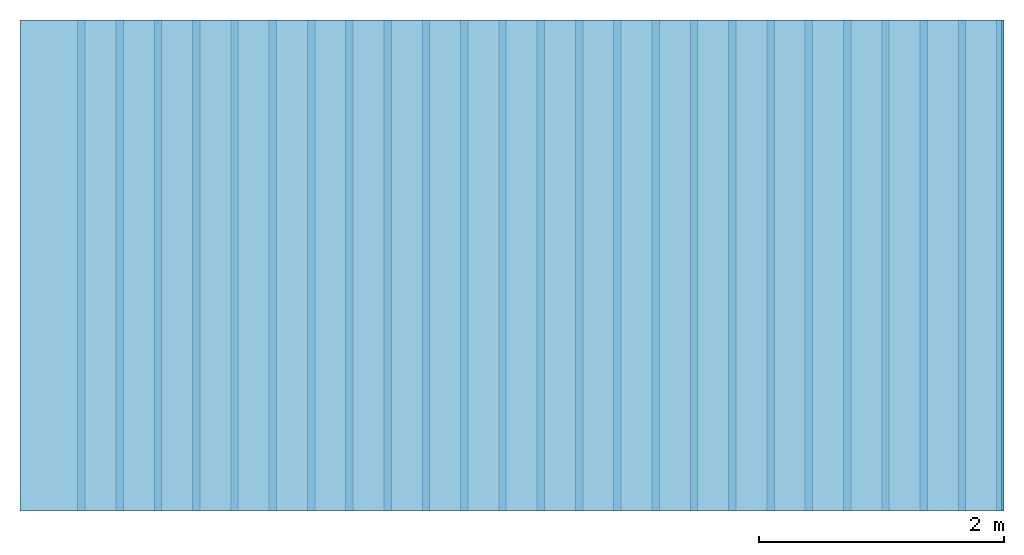
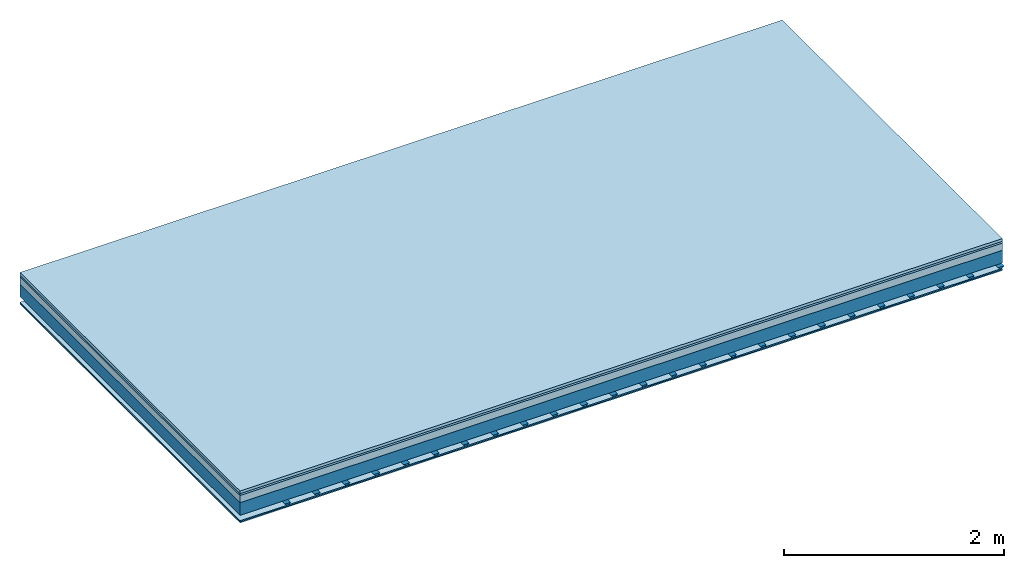
# One storey: 5 plates, 2 members, 1 element without a shape of its own.
"""IFC4 building model written with IfcOpenShell, lengths in metres."""

from ifc_helpers import new_model, si_unit, derived_unit, direction, frame, frame_2d, origin, origin_with_axes, place, context, project, spatial, polyline, rectangle, outline, extrude, material, layer, layer_set, type_object, element, aggregate, save


model = new_model("IFC4")

# Units and contexts
plan_context = context("Plan", 3, precision=1e-05, world=origin(), true_north=direction((0.0, 1.0)))
model_context = context("Model", 3, precision=1e-05, world=origin(), true_north=direction((0.0, 1.0)))
ifc_project = project(units=[si_unit("LENGTHUNIT", "METRE"), derived_unit("SOUNDPRESSUREUNIT", [(si_unit("PRESSUREUNIT", "PASCAL", prefix="MICRO"), 0)]), si_unit("ENERGYUNIT", "JOULE", prefix="MEGA"), si_unit("MASSUNIT", "GRAM", prefix="KILO"), derived_unit("THERMALTRANSMITTANCEUNIT", [(si_unit("POWERUNIT", "WATT"), 1), (si_unit("AREAUNIT", "SQUARE_METRE"), -1), (si_unit("THERMODYNAMICTEMPERATUREUNIT", "KELVIN"), -1)]), derived_unit("AREADENSITYUNIT", [(si_unit("MASSUNIT", "GRAM", prefix="KILO"), 1), (si_unit("AREAUNIT", "SQUARE_METRE"), -1)]), derived_unit("USERDEFINED", [(si_unit("ENERGYUNIT", "JOULE", prefix="MEGA"), 1), (si_unit("AREAUNIT", "SQUARE_METRE"), -1)])], contexts=[plan_context, model_context])

# Site, building, storey
site = spatial("IfcSite", under=ifc_project)
building_placement = place(None, origin())
building = spatial("IfcBuilding", under=site, at=building_placement)
storey_placement = place(building_placement, origin())
storey = spatial("IfcBuildingStorey", under=building, at=storey_placement)

# Slab, members, plates
ifc_material_1 = material(Name="Phone Star TRI", Category="03.013")
ifc_layer_1 = layer(ifc_material_1, 0.03, Name="On-material")
ifc_material_2 = material(Name="EP3")
ifc_layer_2 = layer(ifc_material_2, 0.02, Name="Impact sound insulation")
ifc_material_3 = material(Category="03.011")
ifc_layer_3 = layer(ifc_material_3, 0.08, Name="on Supporting structure")
ifc_material_4 = material(Name="no composite action")
ifc_layer_4 = layer(ifc_material_4, 0.0, Name="Bond")
ifc_layer_5 = layer(None, 0.14, Name="Supporting structure")
ifc_material_5 = material(Name="of the art")
ifc_layer_6 = layer(ifc_material_5, 0.0, Name="Bond")
ifc_layer_7 = layer(None, 0.06, Name="Coupling")
ifc_layer_8 = layer(ifc_material_1, 0.0125, Name="Ceiling covering 1st layer")
ifc_material_6 = material(Name="Plasterboard type A", Category="03.008")
ifc_layer_9 = layer(ifc_material_6, 0.0125, Name="Ceiling covering layer 2")
ifc_material_7 = material(Name="joints", Category="04.017")
ifc_layer_10 = layer(ifc_material_7, 0.0, Name="Surface / treatment")
ifc_layer_set = layer_set([ifc_layer_1, ifc_layer_2, ifc_layer_3, ifc_layer_4, ifc_layer_5, ifc_layer_6, ifc_layer_7, ifc_layer_8, ifc_layer_9, ifc_layer_10])
slab_type = type_object("IfcSlabType", Name="A2425", PredefinedType="NOTDEFINED", material=ifc_layer_set)
slab_placement = place(None, frame((0.0, 0.0, 0.0), z_axis=(0.0, 0.0, -1.0), x_axis=(1.0, 0.0, 0.0)))
slab = element("IfcSlab", 1, at=slab_placement, inside=storey, type_object=slab_type, material=ifc_layer_set, Name="Slab #1")
ifc_material_8 = material()
member_1_placement = place(slab_placement, origin())
member_1 = element("IfcMember", 2, at=member_1_placement, material=ifc_material_8, Name="Supporting structure", context=plan_context, shape_type="SweptSolid", body=[
    extrude(rectangle(XDim=1.0, YDim=0.14, at=frame_2d((0.5, 0.07), x_axis=(1.0, 0.0))), frame((0.0, 4.0, 0.13), z_axis=(0.0, -1.0, 0.0), x_axis=(1.0, 0.0, 0.0)), (0.0, 0.0, 1.0), 4.0),
    extrude(rectangle(XDim=1.0, YDim=0.14, at=frame_2d((0.5, 0.07), x_axis=(1.0, 0.0))), frame((1.0, 4.0, 0.13), z_axis=(0.0, -1.0, 0.0), x_axis=(1.0, 0.0, 0.0)), (0.0, 0.0, 1.0), 4.0),
    extrude(rectangle(XDim=1.0, YDim=0.14, at=frame_2d((0.5, 0.07), x_axis=(1.0, 0.0))), frame((2.0, 4.0, 0.13), z_axis=(0.0, -1.0, 0.0), x_axis=(1.0, 0.0, 0.0)), (0.0, 0.0, 1.0), 4.0),
    extrude(rectangle(XDim=1.0, YDim=0.14, at=frame_2d((0.5, 0.07), x_axis=(1.0, 0.0))), frame((3.0, 4.0, 0.13), z_axis=(0.0, -1.0, 0.0), x_axis=(1.0, 0.0, 0.0)), (0.0, 0.0, 1.0), 4.0),
    extrude(rectangle(XDim=1.0, YDim=0.14, at=frame_2d((0.5, 0.07), x_axis=(1.0, 0.0))), frame((4.0, 4.0, 0.13), z_axis=(0.0, -1.0, 0.0), x_axis=(1.0, 0.0, 0.0)), (0.0, 0.0, 1.0), 4.0),
    extrude(rectangle(XDim=1.0, YDim=0.14, at=frame_2d((0.5, 0.07), x_axis=(1.0, 0.0))), frame((5.0, 4.0, 0.13), z_axis=(0.0, -1.0, 0.0), x_axis=(1.0, 0.0, 0.0)), (0.0, 0.0, 1.0), 4.0),
    extrude(rectangle(XDim=1.0, YDim=0.14, at=frame_2d((0.5, 0.07), x_axis=(1.0, 0.0))), frame((6.0, 4.0, 0.13), z_axis=(0.0, -1.0, 0.0), x_axis=(1.0, 0.0, 0.0)), (0.0, 0.0, 1.0), 4.0),
    extrude(rectangle(XDim=1.0, YDim=0.14, at=frame_2d((0.5, 0.07), x_axis=(1.0, 0.0))), frame((7.0, 4.0, 0.13), z_axis=(0.0, -1.0, 0.0), x_axis=(1.0, 0.0, 0.0)), (0.0, 0.0, 1.0), 4.0),
])
ifc_material_9 = material()
member_2_placement = place(slab_placement, origin())
member_2 = element("IfcMember", 3, at=member_2_placement, material=ifc_material_9, Name="Coupling", context=plan_context, shape_type="SweptSolid", body=[
    extrude(outline(polyline([(0.0, 0.0), (0.06, 0.0), (0.04, 0.02), (0.02, 0.02), (0.0, 0.0)])), frame((0.47, 4.0, 0.31), z_axis=(0.0, -1.0, 0.0), x_axis=(1.0, 0.0, 0.0)), (0.0, 0.0, 1.0), 4.0),
    extrude(outline(polyline([(0.0, 0.0), (0.06, 0.0), (0.04, 0.02), (0.02, 0.02), (0.0, 0.0)])), frame((0.782, 4.0, 0.31), z_axis=(0.0, -1.0, 0.0), x_axis=(1.0, 0.0, 0.0)), (0.0, 0.0, 1.0), 4.0),
    extrude(outline(polyline([(0.0, 0.0), (0.06, 0.0), (0.04, 0.02), (0.02, 0.02), (0.0, 0.0)])), frame((1.094, 4.0, 0.31), z_axis=(0.0, -1.0, 0.0), x_axis=(1.0, 0.0, 0.0)), (0.0, 0.0, 1.0), 4.0),
    extrude(outline(polyline([(0.0, 0.0), (0.06, 0.0), (0.04, 0.02), (0.02, 0.02), (0.0, 0.0)])), frame((1.406, 4.0, 0.31), z_axis=(0.0, -1.0, 0.0), x_axis=(1.0, 0.0, 0.0)), (0.0, 0.0, 1.0), 4.0),
    extrude(outline(polyline([(0.0, 0.0), (0.06, 0.0), (0.04, 0.02), (0.02, 0.02), (0.0, 0.0)])), frame((1.718, 4.0, 0.31), z_axis=(0.0, -1.0, 0.0), x_axis=(1.0, 0.0, 0.0)), (0.0, 0.0, 1.0), 4.0),
    extrude(outline(polyline([(0.0, 0.0), (0.06, 0.0), (0.04, 0.02), (0.02, 0.02), (0.0, 0.0)])), frame((2.03, 4.0, 0.31), z_axis=(0.0, -1.0, 0.0), x_axis=(1.0, 0.0, 0.0)), (0.0, 0.0, 1.0), 4.0),
    extrude(outline(polyline([(0.0, 0.0), (0.06, 0.0), (0.04, 0.02), (0.02, 0.02), (0.0, 0.0)])), frame((2.342, 4.0, 0.31), z_axis=(0.0, -1.0, 0.0), x_axis=(1.0, 0.0, 0.0)), (0.0, 0.0, 1.0), 4.0),
    extrude(outline(polyline([(0.0, 0.0), (0.06, 0.0), (0.04, 0.02), (0.02, 0.02), (0.0, 0.0)])), frame((2.654, 4.0, 0.31), z_axis=(0.0, -1.0, 0.0), x_axis=(1.0, 0.0, 0.0)), (0.0, 0.0, 1.0), 4.0),
    extrude(outline(polyline([(0.0, 0.0), (0.06, 0.0), (0.04, 0.02), (0.02, 0.02), (0.0, 0.0)])), frame((2.966, 4.0, 0.31), z_axis=(0.0, -1.0, 0.0), x_axis=(1.0, 0.0, 0.0)), (0.0, 0.0, 1.0), 4.0),
    extrude(outline(polyline([(0.0, 0.0), (0.06, 0.0), (0.04, 0.02), (0.02, 0.02), (0.0, 0.0)])), frame((3.278, 4.0, 0.31), z_axis=(0.0, -1.0, 0.0), x_axis=(1.0, 0.0, 0.0)), (0.0, 0.0, 1.0), 4.0),
    extrude(outline(polyline([(0.0, 0.0), (0.06, 0.0), (0.04, 0.02), (0.02, 0.02), (0.0, 0.0)])), frame((3.59, 4.0, 0.31), z_axis=(0.0, -1.0, 0.0), x_axis=(1.0, 0.0, 0.0)), (0.0, 0.0, 1.0), 4.0),
    extrude(outline(polyline([(0.0, 0.0), (0.06, 0.0), (0.04, 0.02), (0.02, 0.02), (0.0, 0.0)])), frame((3.902, 4.0, 0.31), z_axis=(0.0, -1.0, 0.0), x_axis=(1.0, 0.0, 0.0)), (0.0, 0.0, 1.0), 4.0),
    extrude(outline(polyline([(0.0, 0.0), (0.06, 0.0), (0.04, 0.02), (0.02, 0.02), (0.0, 0.0)])), frame((4.214, 4.0, 0.31), z_axis=(0.0, -1.0, 0.0), x_axis=(1.0, 0.0, 0.0)), (0.0, 0.0, 1.0), 4.0),
    extrude(outline(polyline([(0.0, 0.0), (0.06, 0.0), (0.04, 0.02), (0.02, 0.02), (0.0, 0.0)])), frame((4.526, 4.0, 0.31), z_axis=(0.0, -1.0, 0.0), x_axis=(1.0, 0.0, 0.0)), (0.0, 0.0, 1.0), 4.0),
    extrude(outline(polyline([(0.0, 0.0), (0.06, 0.0), (0.04, 0.02), (0.02, 0.02), (0.0, 0.0)])), frame((4.838, 4.0, 0.31), z_axis=(0.0, -1.0, 0.0), x_axis=(1.0, 0.0, 0.0)), (0.0, 0.0, 1.0), 4.0),
    extrude(outline(polyline([(0.0, 0.0), (0.06, 0.0), (0.04, 0.02), (0.02, 0.02), (0.0, 0.0)])), frame((5.15, 4.0, 0.31), z_axis=(0.0, -1.0, 0.0), x_axis=(1.0, 0.0, 0.0)), (0.0, 0.0, 1.0), 4.0),
    extrude(outline(polyline([(0.0, 0.0), (0.06, 0.0), (0.04, 0.02), (0.02, 0.02), (0.0, 0.0)])), frame((5.462, 4.0, 0.31), z_axis=(0.0, -1.0, 0.0), x_axis=(1.0, 0.0, 0.0)), (0.0, 0.0, 1.0), 4.0),
    extrude(outline(polyline([(0.0, 0.0), (0.06, 0.0), (0.04, 0.02), (0.02, 0.02), (0.0, 0.0)])), frame((5.774, 4.0, 0.31), z_axis=(0.0, -1.0, 0.0), x_axis=(1.0, 0.0, 0.0)), (0.0, 0.0, 1.0), 4.0),
    extrude(outline(polyline([(0.0, 0.0), (0.06, 0.0), (0.04, 0.02), (0.02, 0.02), (0.0, 0.0)])), frame((6.086, 4.0, 0.31), z_axis=(0.0, -1.0, 0.0), x_axis=(1.0, 0.0, 0.0)), (0.0, 0.0, 1.0), 4.0),
    extrude(outline(polyline([(0.0, 0.0), (0.06, 0.0), (0.04, 0.02), (0.02, 0.02), (0.0, 0.0)])), frame((6.398, 4.0, 0.31), z_axis=(0.0, -1.0, 0.0), x_axis=(1.0, 0.0, 0.0)), (0.0, 0.0, 1.0), 4.0),
    extrude(outline(polyline([(0.0, 0.0), (0.06, 0.0), (0.04, 0.02), (0.02, 0.02), (0.0, 0.0)])), frame((6.71, 4.0, 0.31), z_axis=(0.0, -1.0, 0.0), x_axis=(1.0, 0.0, 0.0)), (0.0, 0.0, 1.0), 4.0),
    extrude(outline(polyline([(0.0, 0.0), (0.06, 0.0), (0.04, 0.02), (0.02, 0.02), (0.0, 0.0)])), frame((7.022, 4.0, 0.31), z_axis=(0.0, -1.0, 0.0), x_axis=(1.0, 0.0, 0.0)), (0.0, 0.0, 1.0), 4.0),
    extrude(outline(polyline([(0.0, 0.0), (0.06, 0.0), (0.04, 0.02), (0.02, 0.02), (0.0, 0.0)])), frame((7.334, 4.0, 0.31), z_axis=(0.0, -1.0, 0.0), x_axis=(1.0, 0.0, 0.0)), (0.0, 0.0, 1.0), 4.0),
    extrude(outline(polyline([(0.0, 0.0), (0.06, 0.0), (0.04, 0.02), (0.02, 0.02), (0.0, 0.0)])), frame((7.646, 4.0, 0.31), z_axis=(0.0, -1.0, 0.0), x_axis=(1.0, 0.0, 0.0)), (0.0, 0.0, 1.0), 4.0),
    extrude(outline(polyline([(0.0, 0.0), (0.06, 0.0), (0.04, 0.02), (0.02, 0.02), (0.0, 0.0)])), frame((7.958, 4.0, 0.31), z_axis=(0.0, -1.0, 0.0), x_axis=(1.0, 0.0, 0.0)), (0.0, 0.0, 1.0), 4.0),
])
plate_1_placement = place(slab_placement, origin())
plate_1 = element("IfcPlate", 4, at=plate_1_placement, material=ifc_material_1, Name="On-material", context=plan_context, shape_type="SweptSolid", body=[
    extrude(rectangle(XDim=8.0, YDim=4.0, at=frame_2d((4.0, 2.0), x_axis=(1.0, 0.0))), origin_with_axes(), (0.0, 0.0, 1.0), 0.03),
])
plate_2_placement = place(slab_placement, origin())
plate_2 = element("IfcPlate", 5, at=plate_2_placement, material=ifc_material_2, Name="Impact sound insulation", context=plan_context, shape_type="SweptSolid", body=[
    extrude(rectangle(XDim=8.0, YDim=4.0, at=frame_2d((4.0, 2.0), x_axis=(1.0, 0.0))), frame((0.0, 0.0, 0.03), z_axis=(0.0, 0.0, 1.0), x_axis=(1.0, 0.0, 0.0)), (0.0, 0.0, 1.0), 0.02),
])
plate_3_placement = place(slab_placement, origin())
plate_3 = element("IfcPlate", 6, at=plate_3_placement, material=ifc_material_3, Name="on Supporting structure", context=plan_context, shape_type="SweptSolid", body=[
    extrude(rectangle(XDim=8.0, YDim=4.0, at=frame_2d((4.0, 2.0), x_axis=(1.0, 0.0))), frame((0.0, 0.0, 0.05), z_axis=(0.0, 0.0, 1.0), x_axis=(1.0, 0.0, 0.0)), (0.0, 0.0, 1.0), 0.08),
])
plate_4_placement = place(slab_placement, origin())
plate_4 = element("IfcPlate", 7, at=plate_4_placement, material=ifc_material_1, Name="Ceiling covering 1st layer", context=plan_context, shape_type="SweptSolid", body=[
    extrude(rectangle(XDim=8.0, YDim=4.0, at=frame_2d((4.0, 2.0), x_axis=(1.0, 0.0))), frame((0.0, 0.0, 0.33), z_axis=(0.0, 0.0, 1.0), x_axis=(1.0, 0.0, 0.0)), (0.0, 0.0, 1.0), 0.0125),
])
plate_5_placement = place(slab_placement, origin())
plate_5 = element("IfcPlate", 8, at=plate_5_placement, material=ifc_material_6, Name="Ceiling covering layer 2", context=plan_context, shape_type="SweptSolid", body=[
    extrude(rectangle(XDim=8.0, YDim=4.0, at=frame_2d((4.0, 2.0), x_axis=(1.0, 0.0))), frame((0.0, 0.0, 0.3425), z_axis=(0.0, 0.0, 1.0), x_axis=(1.0, 0.0, 0.0)), (0.0, 0.0, 1.0), 0.0125),
])
aggregate(slab, [plate_1, plate_2, plate_3, member_1, member_2, plate_4, plate_5])

save(model, "model.ifc")
